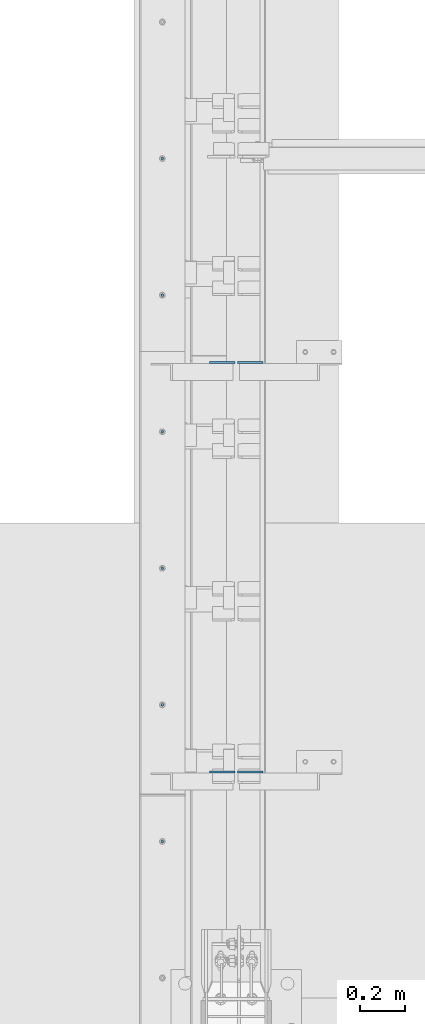
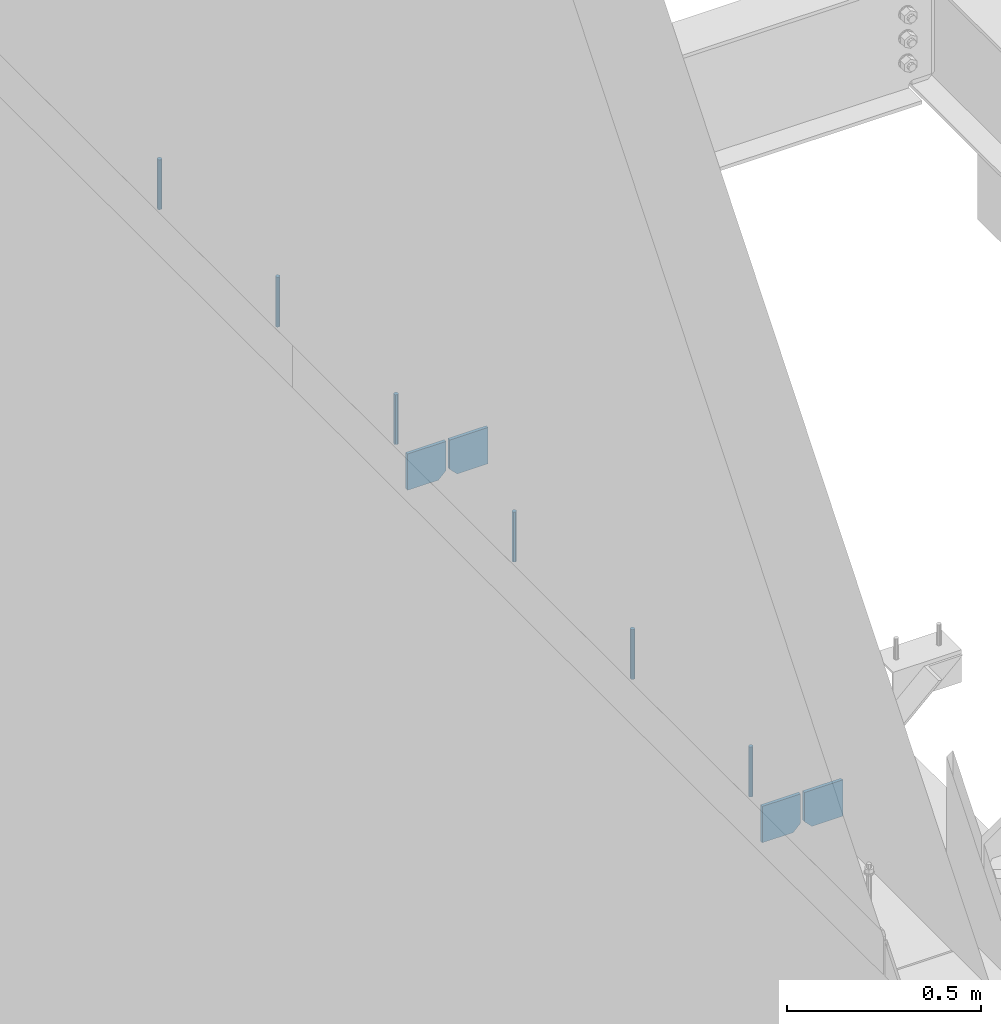
# One storey, part 420 of 1179: 10 columns, 1 element without a shape of its own.
"""IFC2X3 building model written with IfcOpenShell, lengths in millimetres."""

from ifc_helpers import new_model, si_unit, frame, origin_with_axes, place, context, subcontext, project, spatial, faceted_brep, material, type_object, element, aggregate, save


model = new_model("IFC2X3")

# Units and contexts
model_context = context("Model", 3, precision=1e-05, world=origin_with_axes())
body_context = subcontext(model_context, "Body", "Model", "MODEL_VIEW")
ifc_project = project(units=[si_unit("LENGTHUNIT", "METRE", prefix="MILLI"), si_unit("AREAUNIT", "SQUARE_METRE"), si_unit("VOLUMEUNIT", "CUBIC_METRE"), si_unit("MASSUNIT", "GRAM", prefix="KILO"), si_unit("TIMEUNIT", "SECOND"), si_unit("PLANEANGLEUNIT", "RADIAN"), si_unit("SOLIDANGLEUNIT", "STERADIAN"), si_unit("THERMODYNAMICTEMPERATUREUNIT", "DEGREE_CELSIUS"), si_unit("LUMINOUSINTENSITYUNIT", "LUMEN")], contexts=[model_context])

# Site, building, storey
site_placement = place(None, origin_with_axes())
site = spatial("IfcSite", under=ifc_project, at=site_placement, CompositionType="ELEMENT")
building_placement = place(site_placement, origin_with_axes())
building = spatial("IfcBuilding", under=site, at=building_placement, Name="Undefined", CompositionType="ELEMENT")
storey_placement = place(building_placement, origin_with_axes())
storey = spatial("IfcBuildingStorey", under=building, at=storey_placement, Name="Undefined", CompositionType="ELEMENT", Elevation=0.0)

# Assembly, columns
assembly_placement = place(storey_placement, origin_with_axes())
assembly = element("IfcElementAssembly", 1, at=assembly_placement, inside=storey, Name="BEAM", AssemblyPlace="NOTDEFINED", PredefinedType="RIGID_FRAME")
ifc_material_1 = material(Name="STEEL/A36")
column_type_1 = type_object("IfcColumnType", PredefinedType="NOTDEFINED")
column_1_placement = place(assembly_placement, frame((494.506249999995, 22229.7625, 3702.05), z_axis=(-1.0, 0.0, 0.0), x_axis=(0.0, 0.0, 1.0)))
column_1 = element("IfcColumn", 2, at=column_1_placement, type_object=column_type_1, material=ifc_material_1, Name="PLATE", context=body_context, shape_type="Brep", body=[
    faceted_brep([(22.2250000000004, 4.76250000000073, 57.1500000000015), (0.0, 4.76250000000073, 34.9249999999993), (0.0, -4.76250000000073, 34.9249999999993), (22.2250000000004, -4.76250000000073, 57.1500000000015), (114.300000000001, 4.76250000000073, 57.1500000000015), (114.300000000001, 4.76250000000073, -57.1500000000015), (0.0, 4.76250000000073, -57.1500000000015), (114.300000000001, -4.76250000000073, 57.1500000000015), (0.0, -4.76250000000073, -57.1500000000015), (114.300000000001, -4.76250000000073, -57.1500000000015)], [[[0, 1, 2, 3]], [[4, 5, 6, 1, 0]], [[7, 4, 0, 3]], [[8, 9, 7, 3, 2]], [[8, 6, 5, 9]], [[7, 9, 5, 4]], [[6, 8, 2, 1]]]),
])
column_2_placement = place(assembly_placement, frame((369.09375, 22229.7625, 3702.05), z_axis=(1.0, 0.0, 0.0), x_axis=(0.0, 0.0, 1.0)))
column_2 = element("IfcColumn", 3, at=column_2_placement, type_object=column_type_1, material=ifc_material_1, Name="PLATE", context=body_context, shape_type="Brep", body=[
    faceted_brep([(22.2250000000004, 4.76250000000073, 57.1500000000015), (0.0, 4.76250000000073, 34.9249999999993), (0.0, -4.76250000000073, 34.9249999999993), (22.2250000000004, -4.76250000000073, 57.1500000000015), (114.300000000001, 4.76250000000073, 57.1500000000015), (114.300000000001, 4.76250000000073, -57.1500000000015), (0.0, 4.76250000000073, -57.1500000000015), (114.300000000001, -4.76250000000073, 57.1500000000015), (0.0, -4.76250000000073, -57.1500000000015), (114.300000000001, -4.76250000000073, -57.1500000000015)], [[[0, 1, 2, 3]], [[4, 5, 6, 1, 0]], [[7, 4, 0, 3]], [[8, 9, 7, 3, 2]], [[8, 6, 5, 9]], [[7, 9, 5, 4]], [[6, 8, 2, 1]]]),
])
column_3_placement = place(assembly_placement, frame((494.506249999995, 20400.9625, 3702.05), z_axis=(-1.0, 0.0, 0.0), x_axis=(0.0, 0.0, 1.0)))
column_3 = element("IfcColumn", 4, at=column_3_placement, type_object=column_type_1, material=ifc_material_1, Name="PLATE", context=body_context, shape_type="Brep", body=[
    faceted_brep([(22.2250000000004, 4.76250000000073, 57.1500000000015), (0.0, 4.76250000000073, 34.9249999999993), (0.0, -4.76250000000073, 34.9249999999993), (22.2250000000004, -4.76250000000073, 57.1500000000015), (114.300000000001, 4.76250000000073, 57.1500000000015), (114.300000000001, 4.76250000000073, -57.1500000000015), (0.0, 4.76250000000073, -57.1500000000015), (114.300000000001, -4.76250000000073, 57.1500000000015), (0.0, -4.76250000000073, -57.1500000000015), (114.300000000001, -4.76250000000073, -57.1500000000015)], [[[0, 1, 2, 3]], [[4, 5, 6, 1, 0]], [[7, 4, 0, 3]], [[8, 9, 7, 3, 2]], [[8, 6, 5, 9]], [[7, 9, 5, 4]], [[6, 8, 2, 1]]]),
])
column_4_placement = place(assembly_placement, frame((369.09375, 20400.9625, 3702.05), z_axis=(1.0, 0.0, 0.0), x_axis=(0.0, 0.0, 1.0)))
column_4 = element("IfcColumn", 5, at=column_4_placement, type_object=column_type_1, material=ifc_material_1, Name="PLATE", context=body_context, shape_type="Brep", body=[
    faceted_brep([(22.2250000000004, 4.76250000000073, 57.1500000000015), (0.0, 4.76250000000073, 34.9249999999993), (0.0, -4.76250000000073, 34.9249999999993), (22.2250000000004, -4.76250000000073, 57.1500000000015), (114.300000000001, 4.76250000000073, 57.1500000000015), (114.300000000001, 4.76250000000073, -57.1500000000015), (0.0, 4.76250000000073, -57.1500000000015), (114.300000000001, -4.76250000000073, 57.1500000000015), (0.0, -4.76250000000073, -57.1500000000015), (114.300000000001, -4.76250000000073, -57.1500000000015)], [[[0, 1, 2, 3]], [[4, 5, 6, 1, 0]], [[7, 4, 0, 3]], [[8, 9, 7, 3, 2]], [[8, 6, 5, 9]], [[7, 9, 5, 4]], [[6, 8, 2, 1]]]),
])
ifc_material_2 = material(Name="STEEL/A307")
column_type_2 = type_object("IfcColumnType", PredefinedType="NOTDEFINED")
column_5_placement = place(assembly_placement, frame((101.599999999999, 23139.4, 4108.45), z_axis=(0.0, 1.0, 0.0), x_axis=(0.0, 0.0, 1.0)))
column_5 = element("IfcColumn", 6, at=column_5_placement, type_object=column_type_2, material=ifc_material_2, Name="THREADED ROD", context=body_context, shape_type="Brep", body=[
    faceted_brep([(0.0, -6.34999999999854, 0.0), (0.0, -4.49012806053361, -4.49012806053452), (157.162499999999, -4.49012806053361, -4.49012806053361), (157.162499999999, -6.34999999999854, 0.0), (0.0, 0.0, -6.34999999999991), (157.162499999999, 0.0, -6.34999999999854), (0.0, 4.49012806053361, -4.49012806053452), (157.162499999999, 4.49012806053361, -4.49012806053361), (0.0, 6.34999999999854, 0.0), (157.162499999999, 6.34999999999854, 0.0), (0.0, 4.49012806053361, 4.49012806053452), (157.162499999999, 4.49012806053361, 4.49012806053361), (0.0, 0.0, 6.34999999999991), (157.162499999999, 0.0, 6.34999999999854), (0.0, -4.49012806053361, 4.49012806053452), (157.162499999999, -4.49012806053361, 4.49012806053361)], [[[0, 1, 2, 3]], [[1, 4, 5, 2]], [[4, 6, 7, 5]], [[6, 8, 9, 7]], [[8, 10, 11, 9]], [[10, 12, 13, 11]], [[12, 14, 15, 13]], [[14, 0, 3, 15]], [[5, 7, 9, 11, 13, 15, 3, 2]], [[14, 12, 10, 8, 6, 4, 1, 0]]]),
])
column_6_placement = place(assembly_placement, frame((101.599999999999, 22529.8, 4108.45), z_axis=(0.0, 1.0, 0.0), x_axis=(0.0, 0.0, 1.0)))
column_6 = element("IfcColumn", 7, at=column_6_placement, type_object=column_type_2, material=ifc_material_2, Name="THREADED ROD", context=body_context, shape_type="Brep", body=[
    faceted_brep([(0.0, -6.34999999999854, 0.0), (0.0, -4.49012806053361, -4.49012806053452), (157.162499999999, -4.49012806053361, -4.49012806053361), (157.162499999999, -6.34999999999854, 0.0), (0.0, 0.0, -6.34999999999991), (157.162499999999, 0.0, -6.34999999999854), (0.0, 4.49012806053361, -4.49012806053452), (157.162499999999, 4.49012806053361, -4.49012806053361), (0.0, 6.34999999999854, 0.0), (157.162499999999, 6.34999999999854, 0.0), (0.0, 4.49012806053361, 4.49012806053452), (157.162499999999, 4.49012806053361, 4.49012806053361), (0.0, 0.0, 6.34999999999991), (157.162499999999, 0.0, 6.34999999999854), (0.0, -4.49012806053361, 4.49012806053452), (157.162499999999, -4.49012806053361, 4.49012806053361)], [[[0, 1, 2, 3]], [[1, 4, 5, 2]], [[4, 6, 7, 5]], [[6, 8, 9, 7]], [[8, 10, 11, 9]], [[10, 12, 13, 11]], [[12, 14, 15, 13]], [[14, 0, 3, 15]], [[5, 7, 9, 11, 13, 15, 3, 2]], [[14, 12, 10, 8, 6, 4, 1, 0]]]),
])
column_7_placement = place(assembly_placement, frame((101.599999999999, 21920.2, 4108.45), z_axis=(0.0, 1.0, 0.0), x_axis=(0.0, 0.0, 1.0)))
column_7 = element("IfcColumn", 8, at=column_7_placement, type_object=column_type_2, material=ifc_material_2, Name="THREADED ROD", context=body_context, shape_type="Brep", body=[
    faceted_brep([(0.0, -6.34999999999854, 0.0), (0.0, -4.49012806053361, -4.49012806053452), (157.162499999999, -4.49012806053361, -4.49012806053361), (157.162499999999, -6.34999999999854, 0.0), (0.0, 0.0, -6.34999999999991), (157.162499999999, 0.0, -6.34999999999854), (0.0, 4.49012806053361, -4.49012806053452), (157.162499999999, 4.49012806053361, -4.49012806053361), (0.0, 6.34999999999854, 0.0), (157.162499999999, 6.34999999999854, 0.0), (0.0, 4.49012806053361, 4.49012806053452), (157.162499999999, 4.49012806053361, 4.49012806053361), (0.0, 0.0, 6.34999999999991), (157.162499999999, 0.0, 6.34999999999854), (0.0, -4.49012806053361, 4.49012806053452), (157.162499999999, -4.49012806053361, 4.49012806053361)], [[[0, 1, 2, 3]], [[1, 4, 5, 2]], [[4, 6, 7, 5]], [[6, 8, 9, 7]], [[8, 10, 11, 9]], [[10, 12, 13, 11]], [[12, 14, 15, 13]], [[14, 0, 3, 15]], [[5, 7, 9, 11, 13, 15, 3, 2]], [[14, 12, 10, 8, 6, 4, 1, 0]]]),
])
column_8_placement = place(assembly_placement, frame((101.599999999999, 21310.6, 4108.45), z_axis=(0.0, 1.0, 0.0), x_axis=(0.0, 0.0, 1.0)))
column_8 = element("IfcColumn", 9, at=column_8_placement, type_object=column_type_2, material=ifc_material_2, Name="THREADED ROD", context=body_context, shape_type="Brep", body=[
    faceted_brep([(0.0, -6.34999999999854, 0.0), (0.0, -4.49012806053361, -4.49012806053452), (157.162499999999, -4.49012806053361, -4.49012806053361), (157.162499999999, -6.34999999999854, 0.0), (0.0, 0.0, -6.34999999999991), (157.162499999999, 0.0, -6.34999999999854), (0.0, 4.49012806053361, -4.49012806053452), (157.162499999999, 4.49012806053361, -4.49012806053361), (0.0, 6.34999999999854, 0.0), (157.162499999999, 6.34999999999854, 0.0), (0.0, 4.49012806053361, 4.49012806053452), (157.162499999999, 4.49012806053361, 4.49012806053361), (0.0, 0.0, 6.34999999999991), (157.162499999999, 0.0, 6.34999999999854), (0.0, -4.49012806053361, 4.49012806053452), (157.162499999999, -4.49012806053361, 4.49012806053361)], [[[0, 1, 2, 3]], [[1, 4, 5, 2]], [[4, 6, 7, 5]], [[6, 8, 9, 7]], [[8, 10, 11, 9]], [[10, 12, 13, 11]], [[12, 14, 15, 13]], [[14, 0, 3, 15]], [[5, 7, 9, 11, 13, 15, 3, 2]], [[14, 12, 10, 8, 6, 4, 1, 0]]]),
])
column_9_placement = place(assembly_placement, frame((101.599999999999, 20701.0, 4108.45), z_axis=(0.0, 1.0, 0.0), x_axis=(0.0, 0.0, 1.0)))
column_9 = element("IfcColumn", 10, at=column_9_placement, type_object=column_type_2, material=ifc_material_2, Name="THREADED ROD", context=body_context, shape_type="Brep", body=[
    faceted_brep([(0.0, -6.34999999999854, 0.0), (0.0, -4.49012806053361, -4.49012806053452), (157.162499999999, -4.49012806053361, -4.49012806053361), (157.162499999999, -6.34999999999854, 0.0), (0.0, 0.0, -6.34999999999991), (157.162499999999, 0.0, -6.34999999999854), (0.0, 4.49012806053361, -4.49012806053452), (157.162499999999, 4.49012806053361, -4.49012806053361), (0.0, 6.34999999999854, 0.0), (157.162499999999, 6.34999999999854, 0.0), (0.0, 4.49012806053361, 4.49012806053452), (157.162499999999, 4.49012806053361, 4.49012806053361), (0.0, 0.0, 6.34999999999991), (157.162499999999, 0.0, 6.34999999999854), (0.0, -4.49012806053361, 4.49012806053452), (157.162499999999, -4.49012806053361, 4.49012806053361)], [[[0, 1, 2, 3]], [[1, 4, 5, 2]], [[4, 6, 7, 5]], [[6, 8, 9, 7]], [[8, 10, 11, 9]], [[10, 12, 13, 11]], [[12, 14, 15, 13]], [[14, 0, 3, 15]], [[5, 7, 9, 11, 13, 15, 3, 2]], [[14, 12, 10, 8, 6, 4, 1, 0]]]),
])
column_10_placement = place(assembly_placement, frame((101.599999999999, 20091.4, 4108.45), z_axis=(0.0, 1.0, 0.0), x_axis=(0.0, 0.0, 1.0)))
column_10 = element("IfcColumn", 11, at=column_10_placement, type_object=column_type_2, material=ifc_material_2, Name="THREADED ROD", context=body_context, shape_type="Brep", body=[
    faceted_brep([(0.0, -6.34999999999854, 0.0), (0.0, -4.49012806053361, -4.49012806053452), (157.162499999999, -4.49012806053361, -4.49012806053361), (157.162499999999, -6.34999999999854, 0.0), (0.0, 0.0, -6.34999999999991), (157.162499999999, 0.0, -6.34999999999854), (0.0, 4.49012806053361, -4.49012806053452), (157.162499999999, 4.49012806053361, -4.49012806053361), (0.0, 6.34999999999854, 0.0), (157.162499999999, 6.34999999999854, 0.0), (0.0, 4.49012806053361, 4.49012806053452), (157.162499999999, 4.49012806053361, 4.49012806053361), (0.0, 0.0, 6.34999999999991), (157.162499999999, 0.0, 6.34999999999854), (0.0, -4.49012806053361, 4.49012806053452), (157.162499999999, -4.49012806053361, 4.49012806053361)], [[[0, 1, 2, 3]], [[1, 4, 5, 2]], [[4, 6, 7, 5]], [[6, 8, 9, 7]], [[8, 10, 11, 9]], [[10, 12, 13, 11]], [[12, 14, 15, 13]], [[14, 0, 3, 15]], [[5, 7, 9, 11, 13, 15, 3, 2]], [[14, 12, 10, 8, 6, 4, 1, 0]]]),
])
aggregate(assembly, [column_5, column_6, column_7, column_8, column_9, column_10, column_1, column_2, column_3, column_4])

save(model, "model.ifc")
